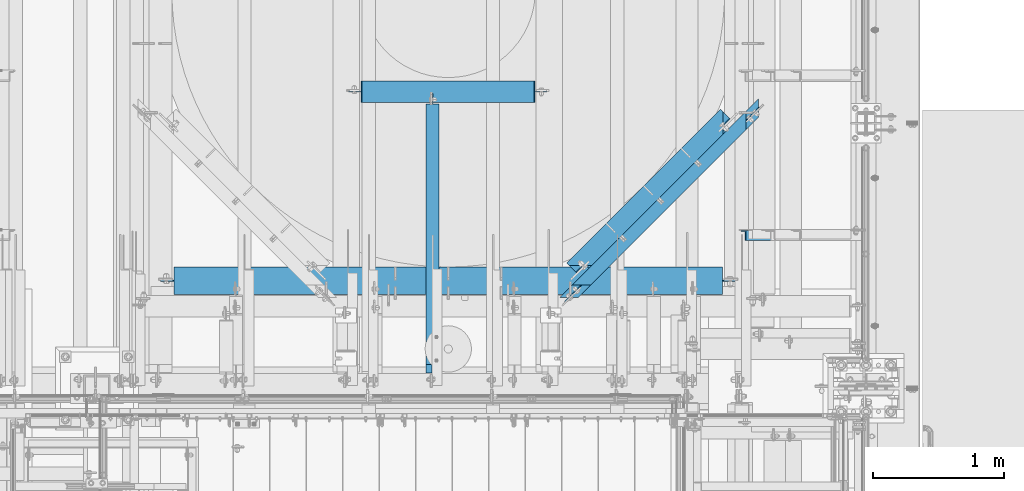
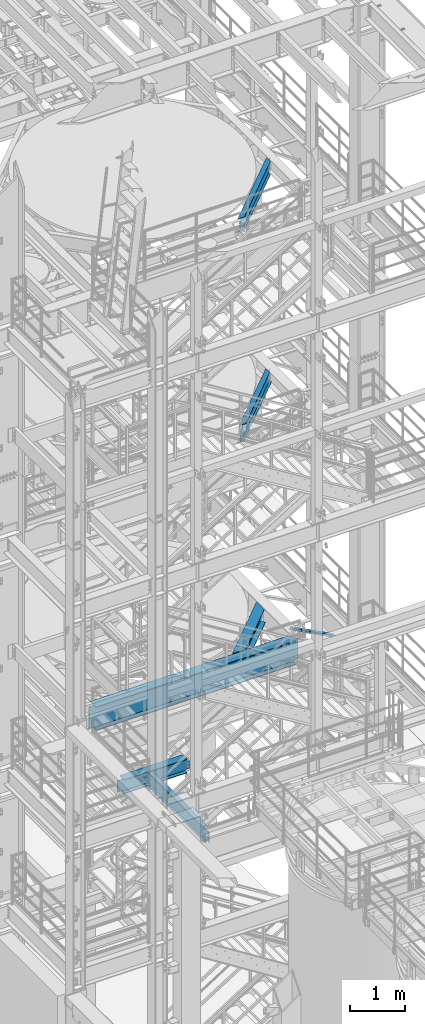
# One storey, part 997 of 1876: 6 beams, 1 member, 7 elements without a shape of their own.
"""IFC2X3 building model written with IfcOpenShell, lengths in millimetres."""

from ifc_helpers import new_model, si_unit, frame, origin_with_axes, place, context, subcontext, project, spatial, faceted_brep, material, type_object, element, aggregate, save


model = new_model("IFC2X3")

# Units and contexts
model_context = context("Model", 3, precision=1e-05, world=origin_with_axes())
body_context = subcontext(model_context, "Body", "Model", "MODEL_VIEW")
ifc_project = project(units=[si_unit("LENGTHUNIT", "METRE", prefix="MILLI"), si_unit("AREAUNIT", "SQUARE_METRE"), si_unit("VOLUMEUNIT", "CUBIC_METRE"), si_unit("MASSUNIT", "GRAM", prefix="KILO"), si_unit("TIMEUNIT", "SECOND"), si_unit("PLANEANGLEUNIT", "RADIAN"), si_unit("SOLIDANGLEUNIT", "STERADIAN"), si_unit("THERMODYNAMICTEMPERATUREUNIT", "DEGREE_CELSIUS"), si_unit("LUMINOUSINTENSITYUNIT", "LUMEN")], contexts=[model_context])

# Site, building, storey
site_placement = place(None, origin_with_axes())
site = spatial("IfcSite", under=ifc_project, at=site_placement, CompositionType="ELEMENT")
building_placement = place(site_placement, origin_with_axes())
building = spatial("IfcBuilding", under=site, at=building_placement, Name="Undefined", CompositionType="ELEMENT")
storey_placement = place(building_placement, origin_with_axes())
storey = spatial("IfcBuildingStorey", under=building, at=storey_placement, Name="Undefined", CompositionType="ELEMENT", Elevation=0.0)

# Assembly, member
assembly_1_placement = place(storey_placement, origin_with_axes())
assembly_1 = element("IfcElementAssembly", 1, at=assembly_1_placement, inside=storey, AssemblyPlace="NOTDEFINED", PredefinedType="RIGID_FRAME")
ifc_material_1 = material(Name="STEEL/A36")
member_type = type_object("IfcMemberType", Name="L3X3X3/8", PredefinedType="NOTDEFINED")
member_placement = place(assembly_1_placement, frame((6618.98281309327, -3400.425, 8122.54466495056), z_axis=(0.0, -1.0, 0.0), x_axis=(0.882670061850832, 0.0, -0.469993150920573)))
member = element("IfcMember", 2, at=member_placement, type_object=member_type, material=ifc_material_1, ObjectType="L3X3X3/8", context=body_context, shape_type="Brep", body=[
    faceted_brep([(70.0788597189262, 38.1000000000258, -38.1), (70.0788597189262, 38.1000000000258, 38.1), (1091.31003699859, 38.1000000003387, 38.1), (1091.31003699859, 38.1000000003387, -38.1), (70.0788597189253, 28.5750000000244, 38.1), (1091.31003699859, 28.5750000003391, 38.1), (70.0788597189253, 28.5750000000244, -28.575), (1091.31003699859, 28.5750000003391, -28.575), (70.0788597189262, -38.0999999999822, -28.575), (1091.31003699859, -38.0999999996675, -28.575), (70.0788597189262, -38.0999999999822, -38.1), (1091.31003699859, -38.0999999996675, -38.1)], [[[0, 1, 2, 3]], [[1, 4, 5, 2]], [[4, 6, 7, 5]], [[6, 8, 9, 7]], [[8, 10, 11, 9]], [[10, 0, 3, 11]], [[5, 7, 9, 11, 3, 2]], [[10, 8, 6, 4, 1, 0]]]),
])
aggregate(assembly_1, [member])

# Assembly, beam
assembly_2_placement = place(storey_placement, origin_with_axes())
assembly_2 = element("IfcElementAssembly", 3, at=assembly_2_placement, inside=storey, Name="BEAM", AssemblyPlace="NOTDEFINED", PredefinedType="RIGID_FRAME")
ifc_material_2 = material(Name="STEEL/A992")
beam_type_1 = type_object("IfcBeamType", Name="W12X16", PredefinedType="NOTDEFINED")
beam_1_placement = place(assembly_2_placement, frame((6903.48911505469, -2316.45279394776, 17830.8), z_axis=(0.0, 0.0, 1.0), x_axis=(-0.707106781186547, -0.707106781186548, 0.0)))
beam_1 = element("IfcBeam", 4, at=beam_1_placement, type_object=beam_type_1, material=ifc_material_2, Name="BEAM", ObjectType="W12X16", context=body_context, shape_type="Brep", body=[
    faceted_brep([(229.151200651399, 3.17500000004202, 146.049999999999), (276.776201863736, 50.8000000000438, 146.049999999999), (2115.27622528938, 50.8000000003867, 146.049999999999), (2162.90122407703, 3.175000000404, 146.049999999999), (2216.87622270634, -50.7999999995791, -152.400000000001), (2216.87622270634, -50.7999999995791, -146.049999999999), (175.176199277681, -50.7999999999602, -146.049999999999), (175.176199277681, -50.7999999999602, -152.400000000001), (2115.27622529269, 50.8000000003867, -152.400000000001), (276.776201863999, 50.8000000000429, -152.400000000001), (2115.27622529269, 50.8000000003867, -146.049999999999), (276.776201863999, 50.8000000000429, -146.049999999999), (2162.90122408034, 3.17500000040218, -146.049999999999), (229.151200651661, 3.17500000004202, -146.049999999999), (2180.33854538134, -3.17499999959273, -132.729229922592), (2173.98854554299, 3.17500000040582, -132.729229922592), (2180.86173582414, 3.17500000040582, -131.762500000004), (2187.21173566249, -3.17499999959091, -131.762500000004), (2174.51173601487, -3.17499999959364, -135.482243823069), (2168.16173617652, 3.175000000404, -135.482243823069), (2170.61838646897, -3.17499999959455, -139.602420291223), (2164.26838663061, 3.17500000040309, -139.602420291223), (2169.25122391869, -3.17499999959455, -144.46249980927), (2162.90122408034, 3.175000000404, -144.46249980927), (2169.25122391869, -3.17499999959455, -146.049999999999), (222.801200490018, -3.17499999995835, -146.049999999999), (222.801200490017, -3.17499999995835, -144.46249980927), (229.151200651661, 3.17500000004202, -144.46249980927), (221.434037904942, -3.17499999995835, -139.602420291223), (227.784038066586, 3.17500000004111, -139.602420291223), (217.540688259932, -3.17499999995835, -135.482243823069), (223.890688421577, 3.17500000004111, -135.482243823069), (211.713878745141, -3.17499999996107, -132.729229922592), (218.063878906786, 3.17500000003929, -132.729229922592), (204.840688289032, -3.17499999996107, -131.762500000004), (211.190688450677, 3.17500000003838, -131.762500000004), (142.297997710428, -3.17499999997381, -131.762500000004), (142.297997710437, 3.17500000002565, -131.762500000004), (142.297997710428, -3.17499999997381, 123.825000000001), (142.297997710437, 3.17500000002565, 123.825000000001), (204.84068828877, -3.17499999996198, 123.825000000001), (211.190688450415, 3.17500000003838, 123.825000000001), (211.713878744878, -3.17499999996016, 124.791729922588), (218.063878906523, 3.1750000000402, 124.791729922588), (217.54068825967, -3.17499999995925, 127.544743823066), (223.890688421315, 3.17500000004111, 127.544743823066), (221.434037904679, -3.17499999995835, 131.664920291219), (227.784038066324, 3.17500000004202, 131.664920291219), (222.801200489755, -3.17499999995835, 136.524999809266), (229.151200651399, 3.17500000004202, 136.524999809266), (276.776201863736, 50.8000000000438, 152.400000000001), (222.801200489756, -3.17499999995835, 146.049999999999), (175.176199277418, -50.7999999999602, 146.049999999999), (175.176199277418, -50.7999999999602, 152.400000000001), (2169.25122391538, -3.17499999959455, 146.049999999999), (2216.87622270303, -50.7999999995782, 146.049999999999), (2216.87622270303, -50.7999999995782, 152.400000000001), (2115.27622528938, 50.8000000003867, 152.400000000001), (2169.25122391538, -3.17499999959546, 136.524999809266), (2162.90122407703, 3.17500000040218, 136.524999809266), (2170.61838646565, -3.17499999959455, 131.664920291219), (2164.2683866273, 3.17500000040309, 131.664920291219), (2174.51173601156, -3.17499999959273, 127.544743823066), (2168.16173617321, 3.175000000404, 127.544743823066), (2180.33854537803, -3.17499999959273, 124.791729922588), (2173.98854553968, 3.17500000040582, 124.791729922588), (2187.21173565918, -3.17499999959182, 123.825000000001), (2180.86173582083, 3.17500000040582, 123.825000000001), (2249.75442416532, -3.17499999958, 123.825000000001), (2249.75442416533, 3.17500000041946, 123.825000000001), (2249.75442416533, 3.17500000041946, -131.762500000004), (2249.75442416532, -3.17499999958, -131.762500000004)], [[[0, 1, 2, 3]], [[4, 5, 6, 7]], [[8, 4, 7, 9]], [[10, 8, 9, 11]], [[12, 10, 11, 13]], [[14, 15, 16, 17]], [[18, 19, 15, 14]], [[20, 21, 19, 18]], [[22, 23, 21, 20]], [[5, 4, 8, 10, 12, 23, 22, 24]], [[5, 24, 25, 6]], [[11, 9, 7, 6, 25, 26, 27, 13]], [[27, 26, 28, 29]], [[29, 28, 30, 31]], [[31, 30, 32, 33]], [[33, 32, 34, 35]], [[35, 34, 36, 37]], [[37, 36, 38, 39]], [[40, 41, 39, 38]], [[41, 40, 42, 43]], [[43, 42, 44, 45]], [[45, 44, 46, 47]], [[47, 46, 48, 49]], [[50, 1, 0, 49, 48, 51, 52, 53]], [[52, 51, 54, 55]], [[53, 52, 55, 56]], [[50, 53, 56, 57]], [[1, 50, 57, 2]], [[56, 55, 54, 58, 59, 3, 2, 57]], [[60, 61, 59, 58]], [[62, 63, 61, 60]], [[64, 65, 63, 62]], [[66, 67, 65, 64]], [[67, 66, 68, 69]], [[16, 15, 19, 21, 23, 12, 13, 27, 29, 31, 33, 35, 37, 39, 41, 43, 45, 47, 49, 0, 3, 59, 61, 63, 65, 67, 69, 70]], [[17, 16, 70, 71]], [[66, 64, 62, 60, 58, 54, 51, 48, 46, 44, 42, 40, 38, 36, 34, 32, 30, 28, 26, 25, 24, 22, 20, 18, 14, 17, 71, 68]], [[70, 69, 68, 71]]]),
])
aggregate(assembly_2, [beam_1])

assembly_3_placement = place(storey_placement, origin_with_axes())
assembly_3 = element("IfcElementAssembly", 5, at=assembly_3_placement, inside=storey, Name="BEAM", AssemblyPlace="NOTDEFINED", PredefinedType="RIGID_FRAME")
beam_2_placement = place(assembly_3_placement, frame((5535.90610564896, -3684.29114297626, 13157.2), z_axis=(0.0, 0.0, 1.0), x_axis=(0.707106781186548, 0.707106781186547, 0.0)))
beam_2 = element("IfcBeam", 6, at=beam_2_placement, type_object=beam_type_1, material=ifc_material_2, Name="BEAM", ObjectType="W12X16", context=body_context, shape_type="Brep", body=[
    faceted_brep([(1696.01646575605, 50.7999999992826, 152.4), (1594.41649478029, -50.8000000006605, 152.4), (1594.41649478029, -50.8000000006605, 146.049999999999), (1642.04148117518, -3.17500000068685, 146.049999999999), (1642.04148117521, -3.17500000068685, 128.587499809264), (1648.3914793612, 3.17499999930897, 128.587499809264), (1648.39147936116, 3.17499999930897, 146.049999999999), (1696.01646575605, 50.7999999992826, 146.049999999999), (1643.40864354761, -3.17500000068776, 123.727420291218), (1649.7586417336, 3.17499999930897, 123.727420291218), (1647.30199258696, -3.17500000068958, 119.607243823064), (1653.65199077295, 3.17499999930715, 119.607243823064), (1653.12880119532, -3.1750000006914, 116.854229922586), (1659.47879938131, 3.17499999930442, 116.854229922586), (1660.00199058222, -3.17500000069413, 115.887499999999), (1666.35198876821, 3.1749999993026, 115.887499999999), (1786.46289533315, 3.17499999925167, 115.887499999999), (1780.11289714716, -3.17500000074597, 115.887499999999), (-321.749380982965, 50.8000000001275, -152.4), (-321.749380982965, 50.8000000001275, -146.049999999999), (1834.08788172807, 50.7999999992244, -146.049999999999), (1834.08788172807, 50.7999999992244, -152.4), (-220.14935195868, -50.7999999999001, -152.4), (1732.48791075224, -50.8000000007178, -152.4), (-220.14935195868, -50.7999999999001, -146.049999999999), (1732.48791075224, -50.8000000007178, -146.049999999999), (-267.774365563814, -3.1749999998874, -146.049999999999), (1780.11289714716, -3.17500000074597, -146.049999999999), (-82.0778965321463, -50.7999999999583, 152.4), (-183.677925556366, 50.8000000000693, 152.4), (-183.677925556366, 50.8000000000693, 146.049999999999), (-136.052911951263, 3.17500000005657, 146.049999999999), (-136.052911951128, 3.17500000005657, 128.587499809264), (-129.70291013711, -3.17499999994561, 128.587499809264), (-129.702910137249, -3.17499999994561, 146.049999999999), (-82.0778965321463, -50.7999999999583, 146.049999999999), (-137.420074714083, 3.17500000005657, 123.727420291218), (-131.070072900066, -3.17499999994379, 123.727420291218), (-141.313424865652, 3.17500000005839, 119.607243823064), (-134.963423051634, -3.17499999994379, 119.607243823064), (-147.140235138563, 3.17500000006112, 116.854229922586), (-140.790233324546, -3.17499999994016, 116.854229922586), (-154.013426488935, 3.17500000006385, 115.887499999999), (-147.663424674917, -3.17499999993743, 115.887499999999), (-274.124367377832, 3.17500000011478, 115.887499999999), (-267.774365563814, -3.1749999998874, 115.887499999999), (-274.124367377832, 3.17500000011478, -146.049999999999), (1786.46289533315, 3.17499999925167, -146.049999999999)], [[[0, 1, 2, 3, 4, 5, 6, 7]], [[5, 4, 8, 9]], [[9, 8, 10, 11]], [[11, 10, 12, 13]], [[13, 12, 14, 15]], [[16, 15, 14, 17]], [[18, 19, 20, 21]], [[22, 18, 21, 23]], [[24, 22, 23, 25]], [[26, 24, 25, 27]], [[28, 29, 30, 31, 32, 33, 34, 35]], [[33, 32, 36, 37]], [[37, 36, 38, 39]], [[39, 38, 40, 41]], [[41, 40, 42, 43]], [[43, 42, 44, 45]], [[46, 19, 18, 22, 24, 26, 45, 44]], [[19, 46, 47, 20]], [[27, 25, 23, 21, 20, 47, 16, 17]], [[12, 10, 8, 4, 3, 34, 33, 37, 39, 41, 43, 45, 26, 27, 17, 14]], [[35, 34, 3, 2]], [[28, 35, 2, 1]], [[29, 28, 1, 0]], [[30, 29, 0, 7]], [[31, 30, 7, 6]], [[47, 46, 44, 42, 40, 38, 36, 32, 31, 6, 5, 9, 11, 13, 15, 16]]]),
])
aggregate(assembly_3, [beam_2])

assembly_4_placement = place(storey_placement, origin_with_axes())
assembly_4 = element("IfcElementAssembly", 7, at=assembly_4_placement, inside=storey, Name="BEAM", AssemblyPlace="NOTDEFINED", PredefinedType="RIGID_FRAME")
beam_3_placement = place(assembly_4_placement, frame((4298.95, -4572.0, 4978.4), z_axis=(0.0, 0.0, 1.0), x_axis=(0.0, 1.0, 0.0)))
beam_3 = element("IfcBeam", 8, at=beam_3_placement, type_object=beam_type_1, material=ifc_material_2, Name="BEAM", ObjectType="W12X16", context=body_context, shape_type="Brep", body=[
    faceted_brep([(2162.175, -3.17500000000018, -146.05), (2162.175, -50.8000000000002, -146.05), (2162.175, -50.8000000000002, -152.4), (2162.175, 50.8000000000002, -152.4), (2162.175, 50.8000000000002, -146.05), (2162.175, 3.17500000000018, -146.05), (2162.175, 3.17500000000018, -139.699999809264), (2162.175, -3.17500000000018, -139.699999809264), (2163.14172992259, 3.17500000000018, -134.839920291219), (2163.14172992259, -3.17500000000018, -134.839920291219), (2165.89474382307, 3.17500000000018, -130.719743823065), (2165.89474382307, -3.17500000000018, -130.719743823065), (2170.01492029122, 3.17500000000018, -127.966729922587), (2170.01492029122, -3.17500000000018, -127.966729922587), (2174.87499980927, 3.17500000000018, -126.999999999999), (2174.87499980927, -3.17500000000018, -126.999999999999), (2257.425, -3.17500000000018, -126.999999999999), (2257.425, 3.17500000000018, -126.999999999999), (181.768749999998, 3.17499999999995, 146.05), (181.768749999998, 50.8, 146.05), (2178.05, 50.8000000000002, 146.05), (2178.05, 3.17500000000018, 146.05), (118.268749999998, -3.17499999999995, -139.699999809265), (118.268749999998, 3.17500002616043, -139.699999809265), (118.268749999998, 3.17500008940715, -146.05), (118.268749999998, 50.8000000000002, -146.05), (118.268749999998, 50.8000000000002, -152.4), (118.268749999998, -50.8, -152.4), (118.268749999998, -50.8, -146.05), (118.268749999998, -3.17499999999995, -146.05), (117.302020077411, -3.17499999999995, -134.83992029122), (117.302020077411, 3.17500002537099, -134.83992029122), (114.549006176932, -3.17499999999995, -130.719743823066), (114.549006176932, 3.17500002470138, -130.719743823066), (110.428829708779, -3.17499999999995, -127.966729922588), (110.428829708779, 3.17500002425345, -127.966729922588), (105.568750190733, -3.17499999999995, -127.0), (105.568750190733, 3.17500002409543, -127.0), (23.0187500000002, -3.17499999999995, -127.0), (23.0187500000002, 3.17499999999995, -127.0), (23.0187500000002, -3.17499999999995, 101.6), (23.0187500000002, 3.17499999999995, 101.6), (169.068750190733, -3.17499999999995, 101.6), (169.068750190733, 3.17499998798007, 101.6), (173.928829708779, -3.17499999999995, 102.566729922588), (173.928829708779, 3.17499998782432, 102.566729922588), (178.049006176932, -3.17499999999995, 105.319743823066), (178.049006176932, 3.17499998738072, 105.319743823066), (180.802020077411, -3.17499999999995, 109.43992029122), (180.802020077411, 3.17499998671678, 109.43992029122), (181.768749999998, -3.17499999999995, 114.299999809266), (181.768749999998, 3.17499998593348, 114.299999809266), (181.768749999998, -50.8, 152.4), (181.768749999998, 50.8, 152.4), (181.768749999998, -3.17499999999995, 146.05), (181.768749999998, -50.8, 146.05), (2178.05, -3.17500000000018, 146.05), (2178.05, -50.8000000000002, 146.05), (2178.05, -50.8000000000002, 152.4), (2178.05, 50.8000000000002, 152.4), (2178.05, -3.17500000000018, 139.699999809266), (2178.05, 3.17500000000018, 139.699999809266), (2179.01672992259, -3.17500000000018, 134.839920291221), (2179.01672992259, 3.17500000000018, 134.839920291221), (2181.76974382307, -3.17500000000018, 130.719743823067), (2181.76974382307, 3.17500000000018, 130.719743823067), (2185.88992029122, -3.17500000000018, 127.966729922588), (2185.88992029122, 3.17500000000018, 127.966729922588), (2190.74999980927, -3.17500000000018, 127.000000000001), (2190.74999980927, 3.17500000000018, 127.000000000001), (2257.425, -3.17500000000018, 127.000000000001), (2257.425, 3.17500000000018, 127.000000000001)], [[[0, 1, 2, 3, 4, 5, 6, 7]], [[7, 6, 8, 9]], [[9, 8, 10, 11]], [[11, 10, 12, 13]], [[13, 12, 14, 15]], [[16, 15, 14, 17]], [[18, 19, 20, 21]], [[22, 23, 24, 25, 26, 27, 28, 29]], [[30, 31, 23, 22]], [[32, 33, 31, 30]], [[34, 35, 33, 32]], [[36, 37, 35, 34]], [[38, 39, 37, 36]], [[40, 41, 39, 38]], [[42, 43, 41, 40]], [[44, 45, 43, 42]], [[46, 47, 45, 44]], [[48, 49, 47, 46]], [[50, 51, 49, 48]], [[52, 53, 19, 18, 51, 50, 54, 55]], [[55, 54, 56, 57]], [[52, 55, 57, 58]], [[53, 52, 58, 59]], [[19, 53, 59, 20]], [[58, 57, 56, 60, 61, 21, 20, 59]], [[62, 63, 61, 60]], [[64, 65, 63, 62]], [[66, 67, 65, 64]], [[68, 69, 67, 66]], [[70, 71, 69, 68]], [[71, 70, 16, 17]], [[12, 10, 8, 6, 5, 24, 23, 31, 33, 35, 37, 39, 41, 43, 45, 47, 49, 51, 18, 21, 61, 63, 65, 67, 69, 71, 17, 14]], [[25, 24, 5, 4]], [[26, 25, 4, 3]], [[27, 26, 3, 2]], [[28, 27, 2, 1]], [[29, 28, 1, 0]], [[70, 68, 66, 64, 62, 60, 56, 54, 50, 48, 46, 44, 42, 40, 38, 36, 34, 32, 30, 22, 29, 0, 7, 9, 11, 13, 15, 16]]]),
])
aggregate(assembly_4, [beam_3])

assembly_5_placement = place(storey_placement, origin_with_axes())
assembly_5 = element("IfcElementAssembly", 9, at=assembly_5_placement, inside=storey, Name="BEAM", AssemblyPlace="NOTDEFINED", PredefinedType="RIGID_FRAME")
beam_type_2 = type_object("IfcBeamType", Name="W12X30", PredefinedType="NOTDEFINED")
beam_4_placement = place(assembly_5_placement, frame((3587.75, -2298.7, 4973.6375), z_axis=(0.0, 0.0, 1.0), x_axis=(1.0, 0.0, 0.0)))
beam_4 = element("IfcBeam", 10, at=beam_4_placement, type_object=beam_type_2, material=ifc_material_2, Name="BEAM", ObjectType="W12X30", context=body_context, shape_type="Brep", body=[
    faceted_brep([(67.4687500000018, -3.17500000000018, -131.7625), (67.4687500000018, 3.17500000000018, -131.7625), (150.018750190737, 3.17500000000018, -131.7625), (150.018750190737, -3.17500000000018, -131.7625), (154.878829708782, 3.17500000000018, -132.729229922587), (154.878829708782, -3.17500000000018, -132.729229922587), (158.999006176936, 3.17500000000018, -135.482243823066), (158.999006176936, -3.17500000000018, -135.482243823066), (161.752020077414, 3.17500000000018, -139.602420291219), (161.752020077414, -3.17500000000018, -139.602420291219), (162.718750000002, -3.17500000000018, -144.462499809265), (162.718750000002, 3.17500000000018, -144.462499809265), (162.718750000002, 3.17500000000018, -146.05), (162.718750000002, 82.5500000000002, -146.05), (162.718750000002, 82.5500000000002, -157.1625), (162.718750000002, -82.5500000000002, -157.1625), (162.718750000002, -82.5500000000002, -146.05), (162.718750000002, -3.17500000000018, -146.05), (1488.28125, 82.5500000000002, 146.05), (1488.28125, 3.17500000000018, 146.05), (169.068750000002, 3.17500000000018, 146.05), (169.068750000002, 82.5500000000002, 146.05), (156.368750190737, -3.17500000000018, 125.4125), (156.368750190737, 3.17500000000018, 125.4125), (67.4687500000018, 3.17500000000018, 125.4125), (67.4687500000018, -3.17500000000018, 125.4125), (161.228829708782, -3.17500000000018, 126.379229922588), (161.228829708782, 3.17500000000018, 126.379229922588), (165.349006176936, -3.17500000000018, 129.132243823066), (165.349006176936, 3.17500000000018, 129.132243823066), (168.102020077414, -3.17500000000018, 133.25242029122), (168.102020077414, 3.17500000000018, 133.25242029122), (169.068750000002, -3.17500000000018, 138.112499809266), (169.068750000002, 3.17500000000018, 138.112499809266), (1488.28125, -82.5500000000002, 157.1625), (1488.28125, 82.5500000000002, 157.1625), (169.068750000002, 82.5500000000002, 157.1625), (169.068750000002, -82.5500000000002, 157.1625), (1488.28125, -82.5500000000002, 146.05), (169.068750000002, -82.5500000000002, 146.05), (1488.28125, -3.17500000000018, 146.05), (169.068750000002, -3.17500000000018, 146.05), (1488.28125, -3.17500000000018, 138.112499809266), (1488.28125, 3.17500000000018, 138.112499809266), (1489.24797992259, -3.17500000000018, 133.25242029122), (1489.24797992259, 3.17500000000018, 133.25242029122), (1492.00099382306, -3.17500000000018, 129.132243823066), (1492.00099382306, 3.17500000000018, 129.132243823066), (1496.12117029122, -3.17500000000018, 126.379229922588), (1496.12117029122, 3.17500000000018, 126.379229922588), (1500.98124980926, -3.17500000000018, 125.4125), (1500.98124980926, 3.17500000000018, 125.4125), (1589.88125, -3.17500000000018, 125.4125), (1589.88125, 3.17500000000018, 125.4125), (1589.88125, -3.17500000000018, -131.7625), (1589.88125, 3.17500000000018, -131.7625), (1507.33124980926, -3.17500000000018, -131.7625), (1507.33124980926, 3.17500000000018, -131.7625), (1502.47117029122, -3.17500000000018, -132.729229922587), (1502.47117029122, 3.17500000000018, -132.729229922587), (1498.35099382306, -3.17500000000018, -135.482243823066), (1498.35099382306, 3.17500000000018, -135.482243823066), (1495.59797992259, -3.17500000000018, -139.602420291219), (1495.59797992259, 3.17500000000018, -139.602420291219), (1494.63125, -3.17500000000018, -144.462499809265), (1494.63125, 3.17500000000018, -144.462499809265), (1494.63125, -3.17500000000018, -146.05), (1494.63125, -82.5500000000002, -146.05), (1494.63125, -82.5500000000002, -157.1625), (1494.63125, 82.5500000000002, -157.1625), (1494.63125, 82.5500000000002, -146.05), (1494.63125, 3.17500000000018, -146.05)], [[[0, 1, 2, 3]], [[3, 2, 4, 5]], [[5, 4, 6, 7]], [[7, 6, 8, 9]], [[10, 11, 12, 13, 14, 15, 16, 17]], [[9, 8, 11, 10]], [[18, 19, 20, 21]], [[22, 23, 24, 25]], [[26, 27, 23, 22]], [[28, 29, 27, 26]], [[30, 31, 29, 28]], [[32, 33, 31, 30]], [[34, 35, 36, 37]], [[38, 34, 37, 39]], [[40, 38, 39, 41]], [[37, 36, 21, 20, 33, 32, 41, 39]], [[35, 18, 21, 36]], [[34, 38, 40, 42, 43, 19, 18, 35]], [[44, 45, 43, 42]], [[46, 47, 45, 44]], [[48, 49, 47, 46]], [[50, 51, 49, 48]], [[52, 53, 51, 50]], [[53, 52, 54, 55]], [[54, 56, 57, 55]], [[58, 59, 57, 56]], [[60, 61, 59, 58]], [[62, 63, 61, 60]], [[64, 65, 63, 62]], [[66, 67, 68, 69, 70, 71, 65, 64]], [[67, 66, 17, 16]], [[68, 67, 16, 15]], [[69, 68, 15, 14]], [[70, 69, 14, 13]], [[71, 70, 13, 12]], [[6, 4, 2, 1, 24, 23, 27, 29, 31, 33, 20, 19, 43, 45, 47, 49, 51, 53, 55, 57, 59, 61, 63, 65, 71, 12, 11, 8]], [[25, 24, 1, 0]], [[66, 64, 62, 60, 58, 56, 54, 52, 50, 48, 46, 44, 42, 40, 41, 32, 30, 28, 26, 22, 25, 0, 3, 5, 7, 9, 10, 17]]]),
])
aggregate(assembly_5, [beam_4])

assembly_6_placement = place(storey_placement, origin_with_axes())
assembly_6 = element("IfcElementAssembly", 11, at=assembly_6_placement, inside=storey, Name="BEAM", AssemblyPlace="NOTDEFINED", PredefinedType="RIGID_FRAME")
beam_type_3 = type_object("IfcBeamType", Name="W14X48", PredefinedType="NOTDEFINED")
beam_5_placement = place(assembly_6_placement, frame((6642.09999997612, -2440.04973148993, 7978.775), z_axis=(0.0, 0.0, 1.0), x_axis=(-0.707106781186547, -0.707106781186548, 0.0)))
beam_5 = element("IfcBeam", 12, at=beam_5_placement, type_object=beam_type_3, material=ifc_material_2, Name="BEAM", ObjectType="W14X48", context=body_context, shape_type="Brep", body=[
    faceted_brep([(1664.18722808035, 3.96875000004911, -158.75), (1664.1874041893, 101.600000000068, -158.75), (185.657751276485, 101.600000000023, -158.75), (185.657575165281, 3.96811089828952, -158.750000051556), (168.736289360735, 3.96875000000455, 150.71492029122), (160.798792301766, -3.96874999999727, 150.71492029122), (162.165954616159, -3.96874999999727, 155.574999809265), (170.103451675127, 3.96875000000455, 155.574999809265), (164.842940486565, 3.96875000000364, 146.594743823066), (156.905443427596, -3.96874999999727, 146.594743823066), (159.016132125415, 3.96875000000364, 143.841729922588), (151.078635066447, -3.96874999999818, 143.841729922588), (152.142943030121, 3.96875000000364, 142.875), (144.205445971152, -3.96874999999818, 142.875), (90.9649929080101, 3.96875000000273, 142.875), (90.9649929080092, -3.96875, 142.875), (1758.88012559206, -101.599999999968, 174.625), (1758.88012559206, -101.599999999968, 158.75), (1758.88012559206, -75.1697674071693, 158.75), (1758.88012559206, -75.1697674071693, 174.625), (90.9649929080101, -101.600000000018, 174.625), (90.9649929080101, -101.600000000018, 158.75), (1687.67908180315, -3.9687499999518, 158.75), (90.9649929080092, -75.1697380898131, 158.75), (162.165954616159, -3.96874999999727, 158.75), (90.9649929080092, -3.96875, -158.75), (1758.88012559206, -3.96874999994907, -158.75), (1758.88012559206, -3.96874999994907, 142.875), (1705.63959710296, -3.96874999995089, 142.875), (1698.76640546098, -3.96874999995089, 143.841729922588), (1692.93959494086, -3.96874999995089, 146.594743823066), (1689.04624462411, -3.9687499999518, 150.71492029122), (1687.67908180315, -3.9687499999518, 155.574999809265), (90.9649929080101, -101.600000000018, -158.75), (1758.88012559206, -101.599999999968, -158.75), (90.9649929080101, -101.600000000018, -174.625), (1758.88012559206, -101.599999999968, -174.625), (1664.1874041893, 101.600000000068, -174.625), (1664.18722807804, 3.96811096761849, -174.625), (1758.88012559206, 3.96794015773594, -174.625), (90.9649929080097, 3.96956232788489, -174.625), (185.657575167596, 3.96939151866172, -174.625), (185.657751276485, 101.600000000023, -174.625), (1758.88012559206, 3.96875000005184, -158.75), (1758.88012559206, 3.96875000005184, -149.217124198765), (1758.88012559206, 3.96875000005184, -92.814990858772), (1758.88012559206, 3.96875000005184, 137.264990578699), (1758.88012559206, 3.96875000005184, 142.875), (1697.70209416192, 3.96875000004911, 142.875), (1690.82890251995, 3.96875000005002, 143.841729922588), (1685.00209199983, 3.96875000004911, 146.594743823066), (1681.10874168308, 3.96875000004911, 150.71492029122), (1679.74157886212, 3.96875000004911, 155.574999809265), (1679.74157886212, 3.96875000004911, 158.75), (1582.11029268738, 101.600000000065, 158.75), (1582.11029268738, 101.600000000065, 174.625), (170.103451675127, 3.96875000000455, 158.75), (267.734665500438, 101.600000000026, 158.75), (267.734665500438, 101.600000000026, 174.625), (90.9649929080092, -75.1697380898131, 174.625), (90.9649929080101, 3.96875000000273, -158.75), (90.9649929080101, 3.96875000000273, -149.232875872044), (90.9649929080101, 3.96875000000273, -92.8150069252915), (90.9649929080101, 3.96875000000273, 137.264997440064)], [[[0, 1, 2, 3]], [[4, 5, 6, 7]], [[8, 9, 5, 4]], [[10, 11, 9, 8]], [[12, 13, 11, 10]], [[14, 15, 13, 12]], [[16, 17, 18, 19]], [[20, 21, 17, 16]], [[22, 18, 17, 21, 23, 24]], [[5, 9, 11, 13, 15, 25, 26, 27, 28, 29, 30, 31, 32, 22, 24, 6]], [[25, 33, 34, 26]], [[33, 35, 36, 34]], [[37, 38, 39, 36, 35, 40, 41, 42]], [[2, 42, 41, 3]], [[1, 37, 42, 2]], [[0, 38, 37, 1]], [[43, 39, 38, 0]], [[44, 45, 46, 47, 27, 26, 34, 36, 39, 43]], [[27, 47, 48, 28]], [[28, 48, 49, 29]], [[29, 49, 50, 30]], [[30, 50, 51, 31]], [[31, 51, 52, 32]], [[19, 18, 22, 32, 52, 53, 54, 55]], [[54, 53, 56, 57]], [[55, 54, 57, 58]], [[20, 16, 19, 55, 58, 59]], [[21, 20, 59, 23]], [[58, 57, 56, 7, 6, 24, 23, 59]], [[53, 52, 51, 50, 49, 48, 47, 46, 45, 44, 43, 0, 3, 60, 61, 62, 63, 14, 12, 10, 8, 4, 7, 56]], [[35, 33, 25, 15, 14, 63, 62, 61, 60, 40]], [[3, 41, 40, 60]]]),
])
aggregate(assembly_6, [beam_5])

assembly_7_placement = place(storey_placement, origin_with_axes())
assembly_7 = element("IfcElementAssembly", 13, at=assembly_7_placement, inside=storey, Name="BEAM", AssemblyPlace="NOTDEFINED", PredefinedType="RIGID_FRAME")
beam_type_4 = type_object("IfcBeamType", Name="W21X68", PredefinedType="NOTDEFINED")
beam_6_placement = place(assembly_7_placement, frame((2197.1, -3748.0875, 7885.1125), z_axis=(0.0, 0.0, 1.0), x_axis=(1.0, 0.0, 0.0)))
beam_6 = element("IfcBeam", 14, at=beam_6_placement, type_object=beam_type_4, material=ifc_material_2, Name="BEAM", ObjectType="W21X68", context=body_context, shape_type="Brep", body=[
    faceted_brep([(4325.14374997612, -5.55625000000009, -250.825), (4325.14374997612, -104.775, -250.825), (4325.14374997612, -104.775, -268.2875), (4325.14374997612, 104.775, -268.2875), (4325.14374997612, 104.775, -250.825), (4325.14374997612, 5.55625000000009, -250.825), (4325.14374997612, 5.55625000000009, -249.237499809264), (4325.14374997612, -5.55625000000009, -249.237499809264), (4326.11047989871, 5.55625000000009, -244.377420291218), (4326.11047989871, -5.55625000000009, -244.377420291218), (4328.86349379918, 5.55625000000009, -240.257243823065), (4328.86349379918, -5.55625000000009, -240.257243823065), (4332.98367026734, 5.55625000000009, -237.504229922586), (4332.98367026734, -5.55625000000009, -237.504229922586), (4337.84374978538, 5.55625000000009, -236.537499999999), (4337.84374978538, -5.55625000000009, -236.537499999999), (4426.74374997612, -5.55625000000009, -236.537499999999), (4426.74374997612, 5.55625000000009, -236.537499999999), (119.856250000001, 5.55625000000009, 250.825), (119.856250000001, 104.775, 250.825), (4325.14374997612, 104.775, 250.825), (4325.14374997612, 5.55625000000009, 250.825), (119.856250000001, -5.55625000000009, -249.237499809264), (119.856250000001, 5.55625000000009, -249.237499809264), (119.856250000001, 5.55625000000009, -250.825), (119.856250000001, 104.775, -250.825), (119.856250000001, 104.775, -268.2875), (119.856250000001, -104.775, -268.2875), (119.856250000001, -104.775, -250.825), (119.856250000001, -5.55625000000009, -250.825), (118.889520077413, -5.55625000000009, -244.377420291218), (118.889520077413, 5.55625000000009, -244.377420291218), (116.136506176935, -5.55625000000009, -240.257243823065), (116.136506176935, 5.55625000000009, -240.257243823065), (112.016329708781, -5.55625000000009, -237.504229922586), (112.016329708781, 5.55625000000009, -237.504229922586), (107.156250190736, -5.55625000000009, -236.537499999999), (107.156250190736, 5.55625000000009, -236.537499999999), (18.2562500000008, -5.55625000000009, -236.537499999999), (18.2562500000008, 5.55625000000009, -236.537499999999), (18.2562500000008, -5.55625000000009, 236.537500000001), (18.2562500000008, 5.55625000000009, 236.537500000001), (107.156250190736, -5.55625000000009, 236.537500000001), (107.156250190736, 5.55625000000009, 236.537500000001), (112.016329708781, -5.55625000000009, 237.504229922589), (112.016329708781, 5.55625000000009, 237.504229922589), (116.136506176935, -5.55625000000009, 240.257243823067), (116.136506176935, 5.55625000000009, 240.257243823067), (118.889520077413, -5.55625000000009, 244.377420291221), (118.889520077413, 5.55625000000009, 244.377420291221), (119.856250000001, -5.55625000000009, 249.237499809266), (119.856250000001, 5.55625000000009, 249.237499809266), (119.856250000001, -104.775, 268.2875), (119.856250000001, 104.775, 268.2875), (119.856250000001, -5.55625000000009, 250.825), (119.856250000001, -104.775, 250.825), (4325.14374997612, -5.55625000000009, 250.825), (4325.14374997612, -104.775, 250.825), (4325.14374997612, -104.775, 268.2875), (4325.14374997612, 104.775, 268.2875), (4325.14374997612, -5.55625000000009, 249.237499809266), (4325.14374997612, 5.55625000000009, 249.237499809266), (4326.11047989871, -5.55625000000009, 244.377420291221), (4326.11047989871, 5.55625000000009, 244.377420291221), (4328.86349379918, -5.55625000000009, 240.257243823067), (4328.86349379918, 5.55625000000009, 240.257243823067), (4332.98367026734, -5.55625000000009, 237.504229922589), (4332.98367026734, 5.55625000000009, 237.504229922589), (4337.84374978538, -5.55625000000009, 236.537500000001), (4337.84374978538, 5.55625000000009, 236.537500000001), (4426.74374997612, -5.55625000000009, 236.537500000001), (4426.74374997612, 5.55625000000009, 236.537500000001)], [[[0, 1, 2, 3, 4, 5, 6, 7]], [[7, 6, 8, 9]], [[9, 8, 10, 11]], [[11, 10, 12, 13]], [[13, 12, 14, 15]], [[16, 15, 14, 17]], [[18, 19, 20, 21]], [[22, 23, 24, 25, 26, 27, 28, 29]], [[30, 31, 23, 22]], [[32, 33, 31, 30]], [[34, 35, 33, 32]], [[36, 37, 35, 34]], [[38, 39, 37, 36]], [[40, 41, 39, 38]], [[42, 43, 41, 40]], [[44, 45, 43, 42]], [[46, 47, 45, 44]], [[48, 49, 47, 46]], [[50, 51, 49, 48]], [[52, 53, 19, 18, 51, 50, 54, 55]], [[55, 54, 56, 57]], [[52, 55, 57, 58]], [[53, 52, 58, 59]], [[19, 53, 59, 20]], [[58, 57, 56, 60, 61, 21, 20, 59]], [[62, 63, 61, 60]], [[64, 65, 63, 62]], [[66, 67, 65, 64]], [[68, 69, 67, 66]], [[70, 71, 69, 68]], [[71, 70, 16, 17]], [[12, 10, 8, 6, 5, 24, 23, 31, 33, 35, 37, 39, 41, 43, 45, 47, 49, 51, 18, 21, 61, 63, 65, 67, 69, 71, 17, 14]], [[25, 24, 5, 4]], [[26, 25, 4, 3]], [[27, 26, 3, 2]], [[28, 27, 2, 1]], [[29, 28, 1, 0]], [[70, 68, 66, 64, 62, 60, 56, 54, 50, 48, 46, 44, 42, 40, 38, 36, 34, 32, 30, 22, 29, 0, 7, 9, 11, 13, 15, 16]]]),
])
aggregate(assembly_7, [beam_6])

save(model, "model.ifc")
